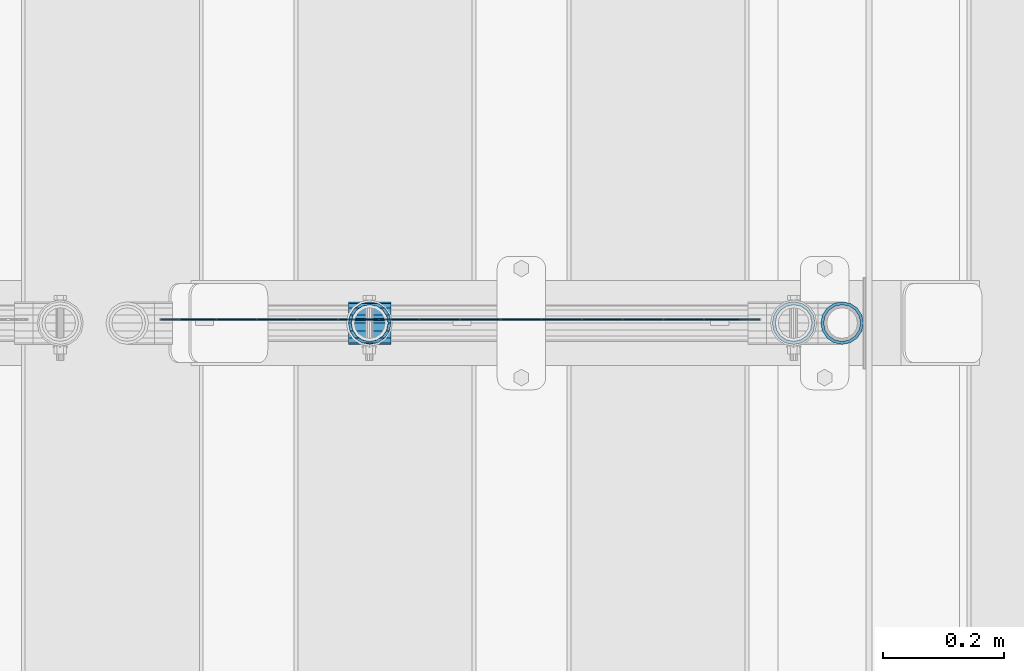
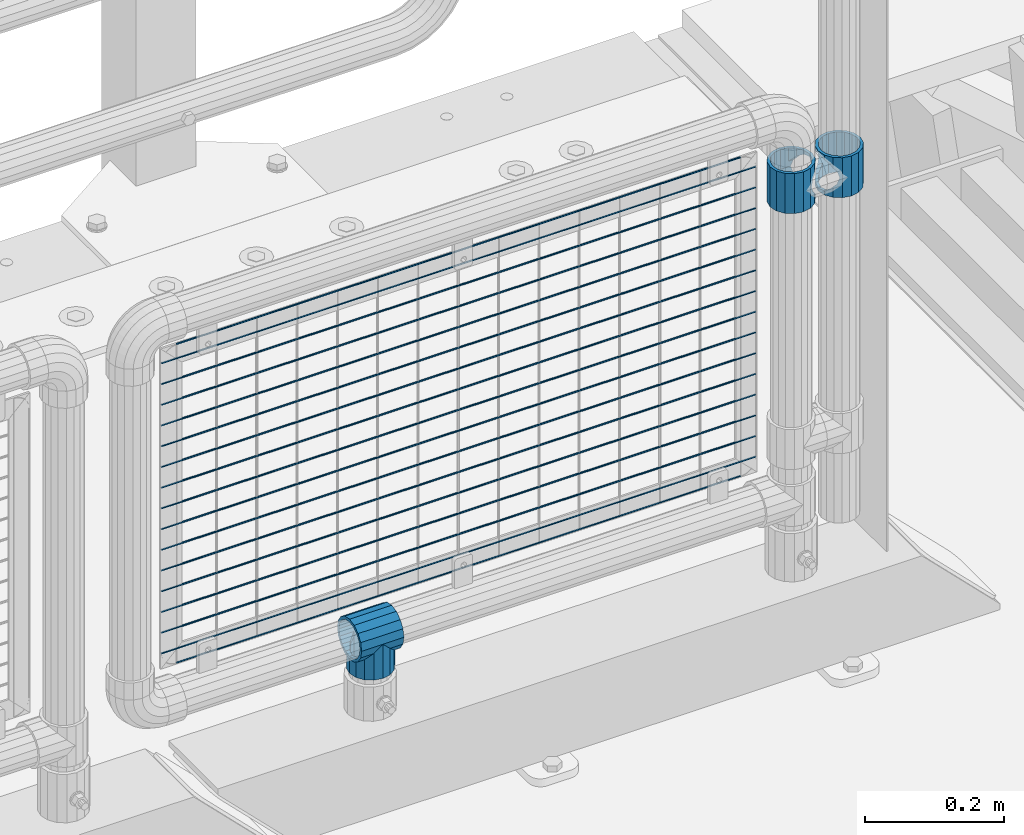
# One storey, part 168 of 242: 21 beams.
"""IFC2X3 building model written with IfcOpenShell, lengths in millimetres."""

from ifc_helpers import new_model, si_unit, frame, origin_with_axes, place, context, subcontext, project, spatial, faceted_brep, material, type_object, element, save


model = new_model("IFC2X3")

# Units and contexts
model_context = context("Model", 3, precision=1e-05, world=origin_with_axes())
body_context = subcontext(model_context, "Body", "Model", "MODEL_VIEW")
ifc_project = project(units=[si_unit("LENGTHUNIT", "METRE", prefix="MILLI"), si_unit("AREAUNIT", "SQUARE_METRE"), si_unit("VOLUMEUNIT", "CUBIC_METRE"), si_unit("MASSUNIT", "GRAM", prefix="KILO"), si_unit("TIMEUNIT", "SECOND"), si_unit("PLANEANGLEUNIT", "RADIAN"), si_unit("SOLIDANGLEUNIT", "STERADIAN"), si_unit("THERMODYNAMICTEMPERATUREUNIT", "DEGREE_CELSIUS"), si_unit("LUMINOUSINTENSITYUNIT", "LUMEN")], contexts=[model_context])

# Site, building, storey
site_placement = place(None, origin_with_axes())
site = spatial("IfcSite", under=ifc_project, at=site_placement, CompositionType="ELEMENT")
building_placement = place(site_placement, origin_with_axes())
building = spatial("IfcBuilding", under=site, at=building_placement, Name="Standard", CompositionType="ELEMENT")
storey_placement = place(building_placement, origin_with_axes())
storey = spatial("IfcBuildingStorey", under=building, at=storey_placement, Name="Undefined", CompositionType="ELEMENT", Elevation=0.0)

# Beams
ifc_material = material(Name="Misc_Undefined")
beam_type_1 = type_object("IfcBeamType", PredefinedType="NOTDEFINED")
beam_1_placement = place(storey_placement, frame((-22656.0, -19335.5, 883.82), z_axis=(-1.0, 0.0, 0.0), x_axis=(0.0, 0.0, -1.0)))
element("IfcBeam", 1, at=beam_1_placement, inside=storey, type_object=beam_type_1, material=ifc_material, context=body_context, shape_type="Brep", body=[
    faceted_brep([(7.11025618828211, -11.614442172282, -32.8397438117172), (7.11025618828211, -11.614442172282, -28.0397438117143), (13.6893091909879, -21.46069080901, -21.4606908090136), (13.6893091909879, -21.46069080901, -27.1226768591077), (8.33762048232484, -13.4513226476338, -32.4743655677739), (23.5355578277191, -28.0397438117179, -11.6144421722784), (23.5355578277191, -28.0397438117179, -20.0882031229921), (18.7689575919975, -24.8548033587067, -24.8548033587067), (35.1500000000015, -30.35, 0.0), (35.1499999999996, -30.3499999999985, -16.6306603983758), (46.7644421722801, -28.0397438117179, -11.6144421722784), (46.7644421722801, -28.0397438117179, -20.0882031229921), (51.5310424079973, -24.8548033587067, -24.8548033587067), (56.6106908090114, -21.46069080901, -21.4606908090136), (56.6106908090114, -21.46069080901, -27.1226768591077), (61.9623795176767, -13.4513226476338, -32.4743655677739), (63.1897438117172, -11.614442172282, -28.0397438117143), (63.1897438117172, -11.614442172282, -32.8397438117172), (65.4999999999997, 0.0, -30.3499999999985), (65.4999999999997, 0.0, -35.1500000000015), (63.1897438117172, 11.614442172282, -28.0397438117143), (63.1897438117172, 11.614442172282, -32.8397438117245), (56.6106908090114, 21.46069080901, -21.4606908090136), (56.6106908090114, 21.46069080901, -27.1226768591077), (61.9623795176744, 13.4513226476338, -32.4743655677739), (46.7644421722801, 28.0397438117179, -11.6144421722784), (46.7644421722801, 28.0397438117179, -20.0882031229849), (51.5310424080006, 24.8548033587067, -24.8548033587067), (35.1500000000015, 30.35, 0.0), (35.1499999999996, 30.3499999999985, -16.6306603983685), (23.5355578277192, 28.0397438117179, -11.6144421722784), (23.5355578277192, 28.0397438117179, -20.0882031229849), (18.7689575919987, 24.8548033587067, -24.8548033587067), (13.6893091909879, 21.46069080901, -21.4606908090136), (13.6893091909879, 21.46069080901, -27.1226768591077), (8.33762048232262, 13.4513226476338, -32.4743655677739), (7.11025618828211, 11.614442172282, -28.0397438117143), (7.11025618828211, 11.614442172282, -32.8397438117245), (4.79999999999961, 0.0, -30.3499999999985), (4.79999999999961, 0.0, -35.1500000000015), (0.0, 21.46069080901, 21.4606908090136), (0.0, 28.0397438117179, 11.6144421722784), (70.2999999999993, 28.0397438117179, 11.6144421722784), (70.2999999999993, 21.46069080901, 21.4606908090136), (0.0, 11.614442172282, 28.0397438117143), (70.2999999999993, 11.614442172282, 28.0397438117143), (0.0, 0.0, 30.3499999999985), (70.2999999999993, 0.0, 30.3499999999985), (0.0, -11.614442172282, 28.0397438117143), (70.2999999999993, -11.614442172282, 28.0397438117143), (0.0, -21.46069080901, 21.4606908090136), (70.2999999999993, -21.46069080901, 21.4606908090136), (0.0, -28.0397438117179, 11.6144421722784), (70.2999999999993, -28.0397438117179, 11.6144421722784), (0.0, -24.8548033587067, -24.8548033587067), (0.0, -13.4513226476338, -32.4743655677739), (0.0, 0.0, -35.1500000000015), (0.0, -32.4743655677703, 13.4513226476338), (0.0, -35.1500000000015, 0.0), (70.2999999999993, -35.1500000000015, 0.0), (70.2999999999993, -32.4743655677703, 13.4513226476338), (0.0, -24.8548033587067, 24.8548033587067), (70.2999999999993, -24.8548033587067, 24.8548033587067), (0.0, -13.4513226476338, 32.4743655677739), (70.2999999999993, -13.4513226476338, 32.4743655677739), (0.0, 0.0, 35.1500000000015), (70.2999999999993, 0.0, 35.1500000000015), (0.0, 13.4513226476338, 32.4743655677739), (70.2999999999993, 13.4513226476338, 32.4743655677739), (0.0, 24.8548033587067, 24.8548033587067), (70.2999999999993, 24.8548033587067, 24.8548033587067), (0.0, 32.4743655677703, 13.4513226476338), (70.2999999999993, 32.4743655677703, 13.4513226476338), (0.0, 35.1500000000015, 0.0), (70.2999999999993, 35.1500000000015, 0.0), (0.0, 32.4743655677703, -13.4513226476338), (70.2999999999993, 32.4743655677703, -13.4513226476338), (70.2999999999993, -13.4513226476338, -32.4743655677739), (70.2999999999993, -24.8548033587067, -24.8548033587067), (70.2999999999993, 0.0, -35.1500000000015), (70.2999999999993, 13.4513226476338, -32.4743655677739), (70.2999999999993, 24.8548033587067, -24.8548033587067), (0.0, 24.8548033587067, -24.8548033587067), (0.0, 13.4513226476338, -32.4743655677739), (70.2999999999993, -32.4743655677703, -13.4513226476338), (0.0, -32.4743655677703, -13.4513226476338), (0.0, -28.0397438117179, -11.6144421722784), (0.0, -21.46069080901, -21.4606908090136), (0.0, -11.614442172282, -28.0397438117143), (0.0, 0.0, -30.3499999999985), (0.0, 11.614442172282, -28.0397438117143), (0.0, 21.46069080901, -21.4606908090136), (0.0, 28.0397438117179, -11.6144421722784), (0.0, 30.3499999999985, 0.0), (0.0, -30.3499999999985, 0.0), (70.2999999999993, 30.3499999999985, 0.0), (70.2999999999993, 28.0397438117179, -11.6144421722784), (70.2999999999993, 21.46069080901, -21.4606908090136), (70.2999999999993, 11.614442172282, -28.0397438117143), (70.2999999999993, 0.0, -30.3499999999985), (70.2999999999993, -11.614442172282, -28.0397438117143), (70.2999999999993, -21.46069080901, -21.4606908090136), (70.2999999999993, -28.0397438117179, -11.6144421722784), (70.2999999999993, -30.3499999999985, 0.0)], [[[0, 1, 2, 3, 4]], [[3, 2, 5, 6, 7]], [[6, 5, 8, 9]], [[9, 8, 10, 11]], [[12, 11, 10, 13, 14]], [[15, 14, 13, 16, 17]], [[17, 16, 18, 19]], [[19, 18, 20, 21]], [[21, 20, 22, 23, 24]], [[23, 22, 25, 26, 27]], [[26, 25, 28, 29]], [[29, 28, 30, 31]], [[32, 31, 30, 33, 34]], [[35, 34, 33, 36, 37]], [[37, 36, 38, 39]], [[39, 38, 1, 0]], [[40, 41, 42, 43]], [[44, 40, 43, 45]], [[46, 44, 45, 47]], [[48, 46, 47, 49]], [[50, 48, 49, 51]], [[52, 50, 51, 53]], [[7, 54, 55, 4, 3]], [[4, 55, 56, 39, 0]], [[57, 58, 59, 60]], [[61, 57, 60, 62]], [[63, 61, 62, 64]], [[65, 63, 64, 66]], [[67, 65, 66, 68]], [[69, 67, 68, 70]], [[71, 69, 70, 72]], [[73, 71, 72, 74]], [[75, 73, 74, 76]], [[77, 78, 12, 14, 15]], [[79, 77, 15, 17, 19]], [[24, 80, 79, 19, 21]], [[27, 81, 80, 24, 23]], [[82, 75, 76, 81, 27, 26, 29, 31, 32]], [[83, 82, 32, 34, 35]], [[56, 83, 35, 37, 39]], [[9, 11, 12, 78, 84, 85, 54, 7, 6]], [[58, 85, 84, 59]], [[57, 61, 63, 65, 67, 69, 71, 73, 75, 82, 83, 56, 55, 54, 85, 58], [86, 87, 88, 89, 90, 91, 92, 93, 41, 40, 44, 46, 48, 50, 52, 94]], [[90, 89, 38, 36]], [[91, 90, 36, 33]], [[92, 91, 33, 30]], [[93, 92, 30, 28]], [[41, 93, 28, 95, 42]], [[96, 95, 28, 25]], [[97, 96, 25, 22]], [[98, 97, 22, 20]], [[99, 98, 20, 18]], [[100, 99, 18, 16]], [[101, 100, 16, 13]], [[102, 101, 13, 10]], [[103, 102, 10, 8]], [[78, 77, 79, 80, 81, 76, 74, 72, 70, 68, 66, 64, 62, 60, 59, 84], [51, 49, 47, 45, 43, 42, 95, 96, 97, 98, 99, 100, 101, 102, 103, 53]], [[8, 94, 52, 53, 103]], [[86, 94, 8, 5]], [[87, 86, 5, 2]], [[88, 87, 2, 1]], [[89, 88, 1, 38]]]),
])
beam_2_placement = place(storey_placement, frame((-22576.0, -19335.5, 883.82), z_axis=(1.0, 0.0, 0.0), x_axis=(0.0, 0.0, -1.0)))
element("IfcBeam", 2, at=beam_2_placement, inside=storey, type_object=beam_type_1, material=ifc_material, context=body_context, shape_type="Brep", body=[
    faceted_brep([(56.6106908090114, 21.46069080901, -27.1226768591077), (56.6106908090114, 21.46069080901, -21.4606908090136), (46.7644421722801, 28.0397438117179, -11.6144421722784), (46.7644421722801, 28.0397438117179, -20.0882031229849), (51.5310424080006, 24.8548033587067, -24.8548033587067), (63.1897438117172, 11.614442172282, -32.8397438117245), (63.1897438117172, 11.614442172282, -28.0397438117143), (61.9623795176744, 13.4513226476338, -32.4743655677739), (65.4999999999997, 0.0, -35.1500000000015), (65.4999999999997, 0.0, -30.3499999999985), (63.1897438117172, -11.614442172282, -32.8397438117172), (63.1897438117172, -11.614442172282, -28.0397438117143), (61.9623795176767, -13.4513226476338, -32.4743655677739), (56.6106908090114, -21.46069080901, -27.1226768591077), (56.6106908090114, -21.46069080901, -21.4606908090136), (51.5310424079973, -24.8548033587067, -24.8548033587067), (46.7644421722801, -28.0397438117179, -20.0882031229921), (46.7644421722801, -28.0397438117179, -11.6144421722784), (35.1499999999996, -30.3499999999985, -16.6306603983758), (35.1500000000015, -30.35, 0.0), (23.5355578277191, -28.0397438117179, -20.0882031229921), (23.5355578277191, -28.0397438117179, -11.6144421722784), (13.6893091909879, -21.46069080901, -27.1226768591077), (13.6893091909879, -21.46069080901, -21.4606908090136), (18.7689575919975, -24.8548033587067, -24.8548033587067), (7.11025618828211, -11.614442172282, -32.8397438117172), (7.11025618828211, -11.614442172282, -28.0397438117143), (8.33762048232484, -13.4513226476338, -32.4743655677739), (4.79999999999961, 0.0, -35.1500000000015), (4.79999999999961, 0.0, -30.3499999999985), (7.11025618828211, 11.614442172282, -32.8397438117245), (7.11025618828211, 11.614442172282, -28.0397438117143), (8.33762048232262, 13.4513226476338, -32.4743655677739), (13.6893091909879, 21.46069080901, -27.1226768591077), (13.6893091909879, 21.46069080901, -21.4606908090136), (18.7689575919987, 24.8548033587067, -24.8548033587067), (23.5355578277192, 28.0397438117179, -20.0882031229849), (23.5355578277192, 28.0397438117179, -11.6144421722784), (35.1499999999996, 30.3499999999985, -16.6306603983685), (35.1500000000015, 30.35, 0.0), (0.0, 32.4743655677703, -13.4513226476338), (0.0, 35.1500000000015, 0.0), (70.2999999999993, 35.1500000000015, 0.0), (70.2999999999993, 32.4743655677703, -13.4513226476338), (0.0, 32.4743655677703, 13.4513226476338), (70.2999999999993, 32.4743655677703, 13.4513226476338), (0.0, 24.8548033587067, 24.8548033587067), (70.2999999999993, 24.8548033587067, 24.8548033587067), (0.0, 13.4513226476338, 32.4743655677739), (70.2999999999993, 13.4513226476338, 32.4743655677739), (0.0, 0.0, 35.1500000000015), (70.2999999999993, 0.0, 35.1500000000015), (0.0, -13.4513226476338, 32.4743655677739), (70.2999999999993, -13.4513226476338, 32.4743655677739), (0.0, -24.8548033587067, 24.8548033587067), (70.2999999999993, -24.8548033587067, 24.8548033587067), (0.0, -32.4743655677703, 13.4513226476338), (70.2999999999993, -32.4743655677703, 13.4513226476338), (0.0, -35.1500000000015, 0.0), (70.2999999999993, -35.1500000000015, 0.0), (70.2999999999993, -30.3499999999985, 0.0), (70.2999999999993, -28.0397438117179, -11.6144421722784), (70.2999999999993, -21.46069080901, -21.4606908090136), (70.2999999999993, -11.614442172282, -28.0397438117143), (70.2999999999993, 0.0, -30.3499999999985), (70.2999999999993, 11.614442172282, -28.0397438117143), (70.2999999999993, 21.46069080901, -21.4606908090136), (70.2999999999993, 28.0397438117179, -11.6144421722784), (0.0, -28.0397438117179, -11.6144421722784), (0.0, -30.3499999999985, 0.0), (0.0, -21.46069080901, -21.4606908090136), (0.0, -11.614442172282, -28.0397438117143), (0.0, 0.0, -30.3499999999985), (0.0, 11.614442172282, -28.0397438117143), (0.0, 21.46069080901, -21.4606908090136), (0.0, 28.0397438117179, -11.6144421722784), (0.0, 30.3499999999985, 0.0), (70.2999999999993, 30.3499999999985, 0.0), (0.0, 28.0397438117179, 11.6144421722784), (70.2999999999993, 28.0397438117179, 11.6144421722784), (0.0, 21.46069080901, 21.4606908090136), (70.2999999999993, 21.46069080901, 21.4606908090136), (0.0, 11.614442172282, 28.0397438117143), (70.2999999999993, 11.614442172282, 28.0397438117143), (0.0, 0.0, 30.3499999999985), (70.2999999999993, 0.0, 30.3499999999985), (0.0, -11.614442172282, 28.0397438117143), (70.2999999999993, -11.614442172282, 28.0397438117143), (0.0, -21.46069080901, 21.4606908090136), (70.2999999999993, -21.46069080901, 21.4606908090136), (0.0, -28.0397438117179, 11.6144421722784), (70.2999999999993, -28.0397438117179, 11.6144421722784), (70.2999999999993, -24.8548033587067, -24.8548033587067), (70.2999999999993, -13.4513226476338, -32.4743655677739), (70.2999999999993, 0.0, -35.1500000000015), (70.2999999999993, 13.4513226476338, -32.4743655677739), (70.2999999999993, 24.8548033587067, -24.8548033587067), (70.2999999999993, -32.4743655677703, -13.4513226476338), (0.0, -32.4743655677703, -13.4513226476338), (0.0, 24.8548033587067, -24.8548033587067), (0.0, 13.4513226476338, -32.4743655677739), (0.0, 0.0, -35.1500000000015), (0.0, -13.4513226476338, -32.4743655677739), (0.0, -24.8548033587067, -24.8548033587067)], [[[0, 1, 2, 3, 4]], [[5, 6, 1, 0, 7]], [[8, 9, 6, 5]], [[10, 11, 9, 8]], [[12, 13, 14, 11, 10]], [[15, 16, 17, 14, 13]], [[18, 19, 17, 16]], [[20, 21, 19, 18]], [[22, 23, 21, 20, 24]], [[25, 26, 23, 22, 27]], [[28, 29, 26, 25]], [[30, 31, 29, 28]], [[32, 33, 34, 31, 30]], [[35, 36, 37, 34, 33]], [[38, 39, 37, 36]], [[3, 2, 39, 38]], [[40, 41, 42, 43]], [[41, 44, 45, 42]], [[44, 46, 47, 45]], [[46, 48, 49, 47]], [[48, 50, 51, 49]], [[50, 52, 53, 51]], [[52, 54, 55, 53]], [[54, 56, 57, 55]], [[56, 58, 59, 57]], [[60, 61, 17, 19]], [[61, 62, 14, 17]], [[62, 63, 11, 14]], [[63, 64, 9, 11]], [[64, 65, 6, 9]], [[65, 66, 1, 6]], [[66, 67, 2, 1]], [[68, 69, 19, 21]], [[70, 68, 21, 23]], [[71, 70, 23, 26]], [[72, 71, 26, 29]], [[73, 72, 29, 31]], [[74, 73, 31, 34]], [[75, 74, 34, 37]], [[76, 75, 37, 39]], [[67, 77, 39, 2]], [[78, 76, 39, 77, 79]], [[80, 78, 79, 81]], [[82, 80, 81, 83]], [[84, 82, 83, 85]], [[86, 84, 85, 87]], [[88, 86, 87, 89]], [[90, 88, 89, 91]], [[19, 69, 90, 91, 60]], [[92, 93, 94, 95, 96, 43, 42, 45, 47, 49, 51, 53, 55, 57, 59, 97], [89, 87, 85, 83, 81, 79, 77, 67, 66, 65, 64, 63, 62, 61, 60, 91]], [[58, 98, 97, 59]], [[56, 54, 52, 50, 48, 46, 44, 41, 40, 99, 100, 101, 102, 103, 98, 58], [68, 70, 71, 72, 73, 74, 75, 76, 78, 80, 82, 84, 86, 88, 90, 69]], [[100, 99, 35, 33, 32]], [[101, 100, 32, 30, 28]], [[27, 102, 101, 28, 25]], [[24, 103, 102, 27, 22]], [[18, 16, 15, 92, 97, 98, 103, 24, 20]], [[93, 92, 15, 13, 12]], [[94, 93, 12, 10, 8]], [[7, 95, 94, 8, 5]], [[4, 96, 95, 7, 0]], [[99, 40, 43, 96, 4, 3, 38, 36, 35]]]),
])
beam_3_placement = place(storey_placement, frame((-23355.39, -19335.5, 298.169999999999), z_axis=(0.0, 1.0, 0.0), x_axis=(0.0, 0.0, -1.0)))
element("IfcBeam", 3, at=beam_3_placement, inside=storey, type_object=beam_type_1, material=ifc_material, context=body_context, shape_type="Brep", body=[
    faceted_brep([(13.4513226476338, 13.4513226476329, 32.4743655677703), (13.4513226476338, -13.4513226476329, 32.4743655677703), (0.0, 0.0, 35.1500000000015), (27.122676859115, -21.4606908090117, -21.46069080901), (24.8548033587067, -16.3810424080019, -24.8548033587067), (24.8548033587067, -24.8548033587072, -24.8548033587067), (32.4743655677739, -32.4743655677717, -13.4513226476338), (32.4743655677739, -26.8123795176754, -13.4513226476338), (0.0, 0.0, -35.1500000000015), (13.4513226476338, -13.4513226476329, -32.4743655677703), (13.4513226476338, 13.4513226476329, -32.4743655677703), (20.0882031229849, -11.6144421722805, -28.0397438117179), (16.6306603983758, 0.0, -30.3499999999985), (20.0882031229849, 11.6144421722805, -28.0397438117179), (24.8548033587067, 16.3810424079986, -24.8548033587067), (24.8548033587067, 24.8548033587072, -24.8548033587067), (27.122676859115, 21.4606908090117, -21.46069080901), (32.4743655677739, 26.8123795176776, -13.4513226476338), (32.4743655677739, 32.4743655677717, -13.4513226476338), (32.8397438117099, 28.0397438117175, -11.614442172282), (35.1500000000015, 30.35, 0.0), (35.1500000000015, 35.1499999999996, 0.0), (32.8397438117172, 28.0397438117175, 11.614442172282), (32.4743655677739, 26.8123795176754, 13.4513226476338), (32.4743655677739, 32.4743655677717, 13.4513226476338), (27.1226768591077, 21.4606908090117, 21.46069080901), (24.8548033587067, 16.3810424080019, 24.8548033587067), (24.8548033587067, 24.8548033587072, 24.8548033587067), (20.0882031229849, 11.6144421722805, 28.0397438117179), (16.6306603983685, 0.0, 30.3499999999985), (20.0882031229849, -11.6144421722805, 28.0397438117179), (24.8548033587067, -16.3810424080019, 24.8548033587067), (24.8548033587067, -24.8548033587072, 24.8548033587067), (32.4743655677739, -26.8123795176754, 13.4513226476338), (32.4743655677739, -32.4743655677717, 13.4513226476338), (27.1226768591077, -21.4606908090117, 21.46069080901), (35.1500000000015, -30.35, 0.0), (35.1500000000015, -35.15, 0.0), (32.8397438117172, -28.0397438117175, 11.614442172282), (32.8397438117099, -28.0397438117175, -11.614442172282), (60.1500000000015, -24.8548033587072, -24.8548033587067), (60.1500000000015, -32.4743655677717, -13.4513226476338), (60.1500000000015, -13.4513226476329, -32.4743655677703), (60.1500000000015, 0.0, -35.1500000000015), (60.1500000000015, 13.4513226476329, -32.4743655677703), (60.1500000000015, 24.8548033587072, -24.8548033587067), (60.1500000000015, 32.4743655677717, -13.4513226476338), (60.1500000000015, 35.15, 0.0), (60.1500000000015, 32.4743655677717, 13.4513226476338), (60.1500000000015, 24.8548033587072, 24.8548033587067), (60.1500000000015, 13.4513226476329, 32.4743655677703), (60.1500000000015, 0.0, 35.1500000000015), (60.1500000000015, -13.4513226476329, 32.4743655677703), (60.1500000000015, -24.8548033587072, 24.8548033587067), (60.1500000000015, -32.4743655677717, 13.4513226476338), (60.1500000000015, -35.15, 0.0), (60.1500000000015, -21.4606908090117, 21.46069080901), (60.1500000000015, -11.6144421722805, 28.0397438117179), (60.1500000000015, 0.0, 30.3499999999985), (60.1500000000015, 11.6144421722805, 28.0397438117179), (60.1500000000015, 21.4606908090117, 21.46069080901), (60.1500000000015, 28.0397438117175, 11.614442172282), (60.1500000000015, 30.35, 0.0), (60.1500000000015, 28.0397438117175, -11.614442172282), (60.1500000000015, 21.4606908090117, -21.46069080901), (60.1500000000015, 11.6144421722805, -28.0397438117179), (60.1500000000015, 0.0, -30.3499999999985), (60.1500000000015, -11.6144421722805, -28.0397438117179), (60.1500000000015, -21.4606908090117, -21.46069080901), (60.1500000000015, -28.0397438117175, -11.614442172282), (60.1500000000015, -30.35, 0.0), (60.1500000000015, -28.0397438117175, 11.614442172282)], [[[0, 1, 2]], [[3, 4, 5, 6, 7]], [[8, 9, 10]], [[10, 9, 5, 4, 11, 12, 13, 14, 15]], [[15, 14, 16, 17, 18]], [[18, 17, 19, 20, 21]], [[21, 20, 22, 23, 24]], [[24, 23, 25, 26, 27]], [[27, 26, 28, 29, 30, 31, 32, 1, 0]], [[33, 34, 32, 31, 35]], [[36, 37, 34, 33, 38]], [[39, 7, 6, 37, 36]], [[40, 41, 6, 5]], [[42, 40, 5, 9]], [[43, 42, 9, 8]], [[44, 43, 8, 10]], [[45, 44, 10, 15]], [[46, 45, 15, 18]], [[47, 46, 18, 21]], [[48, 47, 21, 24]], [[49, 48, 24, 27]], [[50, 49, 27, 0]], [[51, 50, 0, 2]], [[52, 51, 2, 1]], [[53, 52, 1, 32]], [[54, 53, 32, 34]], [[55, 54, 34, 37]], [[41, 55, 37, 6]], [[40, 42, 43, 44, 45, 46, 47, 48, 49, 50, 51, 52, 53, 54, 55, 41], [56, 57, 58, 59, 60, 61, 62, 63, 64, 65, 66, 67, 68, 69, 70, 71]], [[71, 70, 36, 38]], [[35, 56, 71, 38, 33]], [[30, 57, 56, 35, 31]], [[58, 57, 30, 29]], [[59, 58, 29, 28]], [[60, 59, 28, 26, 25]], [[61, 60, 25, 23, 22]], [[62, 61, 22, 20]], [[63, 62, 20, 19]], [[16, 64, 63, 19, 17]], [[13, 65, 64, 16, 14]], [[66, 65, 13, 12]], [[67, 66, 12, 11]], [[68, 67, 11, 4, 3]], [[69, 68, 3, 7, 39]], [[70, 69, 39, 36]]]),
])
beam_4_placement = place(storey_placement, frame((-23390.54, -19335.5, 298.169999999999), z_axis=(0.0, 0.0, 1.0), x_axis=(1.0, 0.0, 0.0)))
element("IfcBeam", 4, at=beam_4_placement, inside=storey, type_object=beam_type_1, material=ifc_material, context=body_context, shape_type="Brep", body=[
    faceted_brep([(61.9623795176767, -13.4513226476338, -32.4743655677739), (56.6106908090114, -21.46069080901, -27.1226768591077), (56.6106908090114, -21.46069080901, -21.4606908090136), (63.1897438117172, -11.614442172282, -28.0397438117143), (63.1897438117172, -11.614442172282, -32.8397438117172), (51.5310424079973, -24.8548033587067, -24.8548033587067), (46.7644421722801, -28.0397438117179, -20.0882031229921), (46.7644421722801, -28.0397438117179, -11.6144421722784), (35.1499999999996, -30.3499999999985, -16.6306603983758), (35.1500000000015, -30.35, 0.0), (23.5355578277191, -28.0397438117179, -20.0882031229921), (23.5355578277191, -28.0397438117179, -11.6144421722784), (13.6893091909879, -21.46069080901, -27.1226768591077), (13.6893091909879, -21.46069080901, -21.4606908090136), (18.7689575919975, -24.8548033587067, -24.8548033587067), (7.11025618828211, -11.614442172282, -32.8397438117172), (7.11025618828211, -11.614442172282, -28.0397438117143), (8.33762048232484, -13.4513226476338, -32.4743655677739), (4.79999999999961, 0.0, -35.1500000000015), (4.79999999999961, 0.0, -30.3499999999985), (7.11025618828211, 11.614442172282, -32.8397438117245), (7.11025618828211, 11.614442172282, -28.0397438117143), (8.33762048232262, 13.4513226476338, -32.4743655677739), (13.6893091909879, 21.46069080901, -27.1226768591077), (13.6893091909879, 21.46069080901, -21.4606908090136), (18.7689575919987, 24.8548033587067, -24.8548033587067), (23.5355578277192, 28.0397438117179, -20.0882031229849), (23.5355578277192, 28.0397438117179, -11.6144421722784), (35.1499999999996, 30.3499999999985, -16.6306603983685), (35.1500000000015, 30.35, 0.0), (46.7644421722801, 28.0397438117179, -20.0882031229849), (46.7644421722801, 28.0397438117179, -11.6144421722784), (56.6106908090114, 21.46069080901, -27.1226768591077), (56.6106908090114, 21.46069080901, -21.4606908090136), (51.5310424080006, 24.8548033587067, -24.8548033587067), (63.1897438117172, 11.614442172282, -32.8397438117245), (63.1897438117172, 11.614442172282, -28.0397438117143), (61.9623795176744, 13.4513226476338, -32.4743655677739), (65.4999999999997, 0.0, -35.1500000000015), (65.4999999999997, 0.0, -30.3499999999985), (0.0, -21.46069080901, -21.4606908090136), (0.0, -28.0397438117179, -11.6144421722784), (0.0, -11.614442172282, -28.0397438117143), (0.0, 0.0, -30.3499999999985), (0.0, 11.614442172282, -28.0397438117143), (0.0, 21.46069080901, -21.4606908090136), (0.0, 28.0397438117179, -11.6144421722784), (0.0, 30.3499999999985, 0.0), (0.0, 32.4743655677703, -13.4513226476338), (0.0, 35.1500000000015, 0.0), (70.2999999999993, 35.1500000000015, 0.0), (70.2999999999993, 32.4743655677703, -13.4513226476338), (0.0, 32.4743655677703, 13.4513226476338), (70.2999999999993, 32.4743655677703, 13.4513226476338), (0.0, 24.8548033587067, 24.8548033587067), (70.2999999999993, 24.8548033587067, 24.8548033587067), (0.0, 13.4513226476338, 32.4743655677739), (70.2999999999993, 13.4513226476338, 32.4743655677739), (0.0, 0.0, 35.1500000000015), (70.2999999999993, 0.0, 35.1500000000015), (0.0, -13.4513226476338, 32.4743655677739), (70.2999999999993, -13.4513226476338, 32.4743655677739), (0.0, -24.8548033587067, 24.8548033587067), (70.2999999999993, -24.8548033587067, 24.8548033587067), (0.0, -32.4743655677703, 13.4513226476338), (70.2999999999993, -32.4743655677703, 13.4513226476338), (0.0, -35.1500000000015, 0.0), (70.2999999999993, -35.1500000000015, 0.0), (0.0, -32.4743655677703, -13.4513226476338), (70.2999999999993, -32.4743655677703, -13.4513226476338), (0.0, 24.8548033587067, -24.8548033587067), (0.0, 13.4513226476338, -32.4743655677739), (0.0, 0.0, -35.1500000000015), (0.0, -13.4513226476338, -32.4743655677739), (0.0, -24.8548033587067, -24.8548033587067), (0.0, 28.0397438117179, 11.6144421722784), (0.0, 21.46069080901, 21.4606908090136), (0.0, 11.614442172282, 28.0397438117143), (0.0, 0.0, 30.3499999999985), (0.0, -11.614442172282, 28.0397438117143), (0.0, -21.46069080901, 21.4606908090136), (0.0, -28.0397438117179, 11.6144421722784), (0.0, -30.3499999999985, 0.0), (70.2999999999993, -30.3499999999985, 0.0), (70.2999999999993, -28.0397438117179, -11.6144421722784), (70.2999999999993, -21.46069080901, -21.4606908090136), (70.2999999999993, -11.614442172282, -28.0397438117143), (70.2999999999993, 0.0, -30.3499999999985), (70.2999999999993, 21.46069080901, -21.4606908090136), (70.2999999999993, 28.0397438117179, -11.6144421722784), (70.2999999999993, 11.614442172282, -28.0397438117143), (70.2999999999993, 30.3499999999985, 0.0), (70.2999999999993, 28.0397438117179, 11.6144421722784), (70.2999999999993, 21.46069080901, 21.4606908090136), (70.2999999999993, 11.614442172282, 28.0397438117143), (70.2999999999993, 0.0, 30.3499999999985), (70.2999999999993, -11.614442172282, 28.0397438117143), (70.2999999999993, -21.46069080901, 21.4606908090136), (70.2999999999993, -28.0397438117179, 11.6144421722784), (70.2999999999993, -24.8548033587067, -24.8548033587067), (70.2999999999993, -13.4513226476338, -32.4743655677739), (70.2999999999993, 0.0, -35.1500000000015), (70.2999999999993, 13.4513226476338, -32.4743655677739), (70.2999999999993, 24.8548033587067, -24.8548033587067)], [[[0, 1, 2, 3, 4]], [[5, 6, 7, 2, 1]], [[8, 9, 7, 6]], [[10, 11, 9, 8]], [[12, 13, 11, 10, 14]], [[15, 16, 13, 12, 17]], [[18, 19, 16, 15]], [[20, 21, 19, 18]], [[22, 23, 24, 21, 20]], [[25, 26, 27, 24, 23]], [[28, 29, 27, 26]], [[30, 31, 29, 28]], [[32, 33, 31, 30, 34]], [[35, 36, 33, 32, 37]], [[38, 39, 36, 35]], [[4, 3, 39, 38]], [[40, 41, 11, 13]], [[42, 40, 13, 16]], [[43, 42, 16, 19]], [[44, 43, 19, 21]], [[45, 44, 21, 24]], [[46, 45, 24, 27]], [[47, 46, 27, 29]], [[48, 49, 50, 51]], [[49, 52, 53, 50]], [[52, 54, 55, 53]], [[54, 56, 57, 55]], [[56, 58, 59, 57]], [[58, 60, 61, 59]], [[60, 62, 63, 61]], [[62, 64, 65, 63]], [[64, 66, 67, 65]], [[66, 68, 69, 67]], [[64, 62, 60, 58, 56, 54, 52, 49, 48, 70, 71, 72, 73, 74, 68, 66], [41, 40, 42, 43, 44, 45, 46, 47, 75, 76, 77, 78, 79, 80, 81, 82]], [[41, 82, 9, 11]], [[83, 84, 7, 9]], [[84, 85, 2, 7]], [[85, 86, 3, 2]], [[86, 87, 39, 3]], [[88, 89, 31, 33]], [[90, 88, 33, 36]], [[87, 90, 36, 39]], [[89, 91, 29, 31]], [[75, 47, 29, 91, 92]], [[76, 75, 92, 93]], [[77, 76, 93, 94]], [[78, 77, 94, 95]], [[79, 78, 95, 96]], [[80, 79, 96, 97]], [[81, 80, 97, 98]], [[9, 82, 81, 98, 83]], [[99, 100, 101, 102, 103, 51, 50, 53, 55, 57, 59, 61, 63, 65, 67, 69], [97, 96, 95, 94, 93, 92, 91, 89, 88, 90, 87, 86, 85, 84, 83, 98]], [[37, 102, 101, 38, 35]], [[34, 103, 102, 37, 32]], [[70, 48, 51, 103, 34, 30, 28, 26, 25]], [[71, 70, 25, 23, 22]], [[72, 71, 22, 20, 18]], [[17, 73, 72, 18, 15]], [[14, 74, 73, 17, 12]], [[8, 6, 5, 99, 69, 68, 74, 14, 10]], [[100, 99, 5, 1, 0]], [[101, 100, 0, 4, 38]]]),
])
beam_type_2 = type_object("IfcBeamType", Name="D3", PredefinedType="NOTDEFINED")
for number, where, z_axis, x_axis in (
    (5, (-23700.39, -19329.5000116654, 633.023), (0.0, 0.0, 1.0), (1.0, 0.0, 0.0)),
    (6, (-23700.39, -19329.5000116615, 815.168), (0.0, 0.0, 1.0), (1.0, 0.0, 0.0)),
    (7, (-23700.39, -19329.5000116646, 669.452), (0.0, 0.0, 1.0), (1.0, 0.0, 0.0)),
    (8, (-23700.39, -19329.5000116662, 596.594000000001), (0.0, 0.0, 1.0), (1.0, 0.0, 0.0)),
    (9, (-23700.39, -19329.5000116669, 560.165), (0.0, 0.0, 1.0), (1.0, 0.0, 0.0)),
    (10, (-23700.39, -19329.5000116623, 778.739), (0.0, 0.0, 1.0), (1.0, 0.0, 0.0)),
    (11, (-23700.39, -19329.5000116677, 523.736), (0.0, 0.0, 1.0), (1.0, 0.0, 0.0)),
    (12, (-23700.39, -19329.5000116608, 851.597), (0.0, 0.0, 1.0), (1.0, 0.0, 0.0)),
    (13, (-23700.39, -19329.5000116685, 487.307), (0.0, 0.0, 1.0), (1.0, 0.0, 0.0)),
    (14, (-23700.39, -19329.5000116639, 705.881), (0.0, 0.0, 1.0), (1.0, 0.0, 0.0)),
    (15, (-23700.39, -19329.5000116692, 450.878), (0.0, 0.0, 1.0), (1.0, 0.0, 0.0)),
    (16, (-23700.39, -19329.50001166, 888.026), (0.0, 0.0, 1.0), (1.0, 0.0, 0.0)),
    (17, (-23700.39, -19329.5000116631, 742.31), (0.0, 0.0, 1.0), (1.0, 0.0, 0.0)),
    (18, (-23700.39, -19329.50001167, 414.449), (0.0, 0.0, 1.0), (1.0, 0.0, 0.0)),
):
    element("IfcBeam", number, at=place(storey_placement, frame(where, z_axis=z_axis, x_axis=x_axis)), inside=storey, type_object=beam_type_2, material=ifc_material, ObjectType="D3", context=body_context, shape_type="Brep", body=[
        faceted_brep([(0.0, -1.50000000000364, 0.0), (-3.63797880709171e-12, -0.750000000003638, -1.29903810567669), (988.390000000236, -0.750000000003638, -1.29903810567669), (988.39000000024, -1.50000000000364, 0.0), (0.0, 0.749999999996362, -1.29903810567669), (988.39000000024, 0.749999999996362, -1.29903810567669), (-3.63797880709171e-12, 1.49999999999636, 0.0), (988.390000000236, 1.49999999999636, 0.0), (0.0, 0.749999999996362, 1.29903810567669), (988.39000000024, 0.749999999996362, 1.29903810567669), (-3.63797880709171e-12, -0.750000000003638, 1.29903810567669), (988.390000000236, -0.750000000003638, 1.29903810567669)], [[[0, 1, 2, 3]], [[1, 4, 5, 2]], [[4, 6, 7, 5]], [[6, 8, 9, 7]], [[8, 10, 11, 9]], [[10, 0, 3, 11]], [[5, 7, 9, 11, 3, 2]], [[10, 8, 6, 4, 1, 0]]]),
    ])
beam_5_placement = place(storey_placement, frame((-23675.39, -19329.5000169757, 353.02), z_axis=(0.0, 0.0, 1.0), x_axis=(1.0, 0.0, 0.0)))
element("IfcBeam", 19, at=beam_5_placement, inside=storey, type_object=beam_type_2, material=ifc_material, ObjectType="D3", context=body_context, shape_type="Brep", body=[
    faceted_brep([(0.0, -1.50000000000364, 0.0), (-3.63797880709171e-12, -0.750000000003638, -1.29903810567669), (938.390000000087, -0.75, -1.29903810567669), (938.39000000009, -1.5, 0.0), (0.0, 0.749999999996362, -1.29903810567669), (938.39000000009, 0.75, -1.29903810567663), (-3.63797880709171e-12, 1.49999999999636, 0.0), (938.39000000009, 1.5, 0.0), (0.0, 0.749999999996362, 1.29903810567669), (938.39000000009, 0.75, 1.29903810567669), (-3.63797880709171e-12, -0.750000000003638, 1.29903810567669), (938.390000000087, -0.75, 1.29903810567669)], [[[0, 1, 2, 3]], [[1, 4, 5, 2]], [[4, 6, 7, 5]], [[6, 8, 9, 7]], [[8, 10, 11, 9]], [[10, 0, 3, 11]], [[5, 7, 9, 11, 3, 2]], [[10, 8, 6, 4, 1, 0]]]),
])
beam_6_placement = place(storey_placement, frame((-23700.39, -19329.5000116708, 378.02), z_axis=(0.0, 0.0, 1.0), x_axis=(1.0, 0.0, 0.0)))
element("IfcBeam", 20, at=beam_6_placement, inside=storey, type_object=beam_type_2, material=ifc_material, ObjectType="D3", context=body_context, shape_type="Brep", body=[
    faceted_brep([(0.0, -1.50000000000364, 0.0), (-3.63797880709171e-12, -0.750000000003638, -1.29903810567669), (988.390000000236, -0.750000000003638, -1.29903810567669), (988.39000000024, -1.50000000000364, 0.0), (0.0, 0.749999999996362, -1.29903810567669), (988.39000000024, 0.749999999996362, -1.29903810567669), (-3.63797880709171e-12, 1.49999999999636, 0.0), (988.390000000236, 1.49999999999636, 0.0), (0.0, 0.749999999996362, 1.29903810567669), (988.39000000024, 0.749999999996362, 1.29903810567669), (-3.63797880709171e-12, -0.750000000003638, 1.29903810567669), (988.390000000236, -0.750000000003638, 1.29903810567669)], [[[0, 1, 2, 3]], [[1, 4, 5, 2]], [[4, 6, 7, 5]], [[6, 8, 9, 7]], [[8, 10, 11, 9]], [[10, 0, 3, 11]], [[5, 7, 9, 11, 3, 2]], [[10, 8, 6, 4, 1, 0]]]),
])
beam_7_placement = place(storey_placement, frame((-23675.39, -19329.50001696, 913.02), z_axis=(0.0, 0.0, 1.0), x_axis=(1.0, 0.0, 0.0)))
element("IfcBeam", 21, at=beam_7_placement, inside=storey, type_object=beam_type_2, material=ifc_material, ObjectType="D3", context=body_context, shape_type="Brep", body=[
    faceted_brep([(0.0, -1.50000000000364, 0.0), (-3.63797880709171e-12, -0.750000000003638, -1.29903810567669), (938.390000000087, -0.75, -1.29903810567669), (938.39000000009, -1.5, 0.0), (0.0, 0.749999999996362, -1.29903810567669), (938.39000000009, 0.75, -1.29903810567663), (-3.63797880709171e-12, 1.49999999999636, 0.0), (938.39000000009, 1.5, 0.0), (0.0, 0.749999999996362, 1.29903810567669), (938.39000000009, 0.75, 1.29903810567669), (-3.63797880709171e-12, -0.750000000003638, 1.29903810567669), (938.390000000087, -0.75, 1.29903810567669)], [[[0, 1, 2, 3]], [[1, 4, 5, 2]], [[4, 6, 7, 5]], [[6, 8, 9, 7]], [[8, 10, 11, 9]], [[10, 0, 3, 11]], [[5, 7, 9, 11, 3, 2]], [[10, 8, 6, 4, 1, 0]]]),
])

save(model, "model.ifc")
